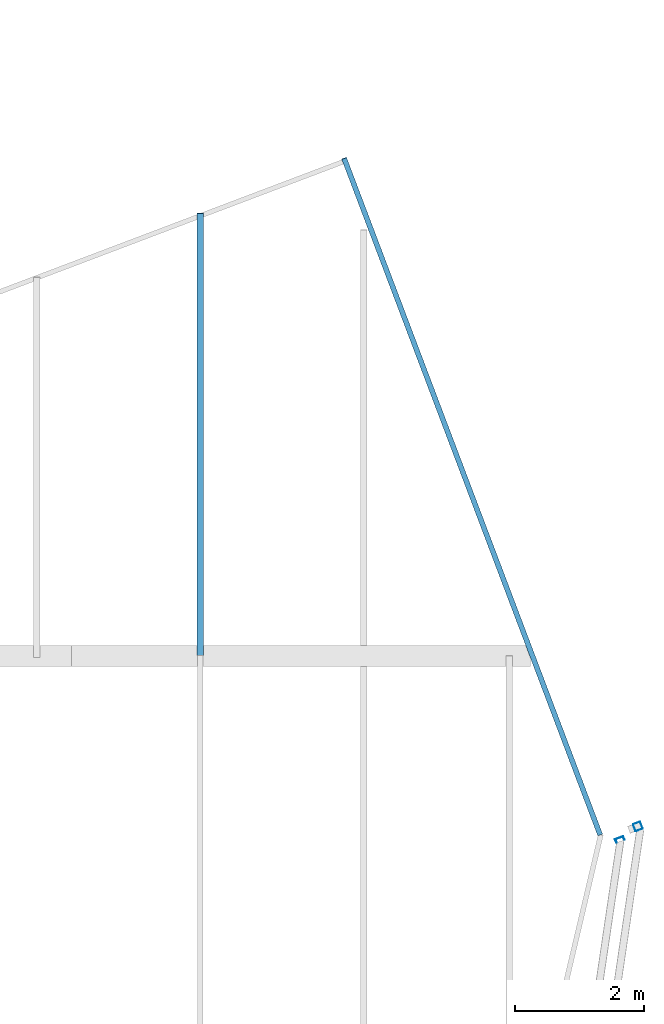
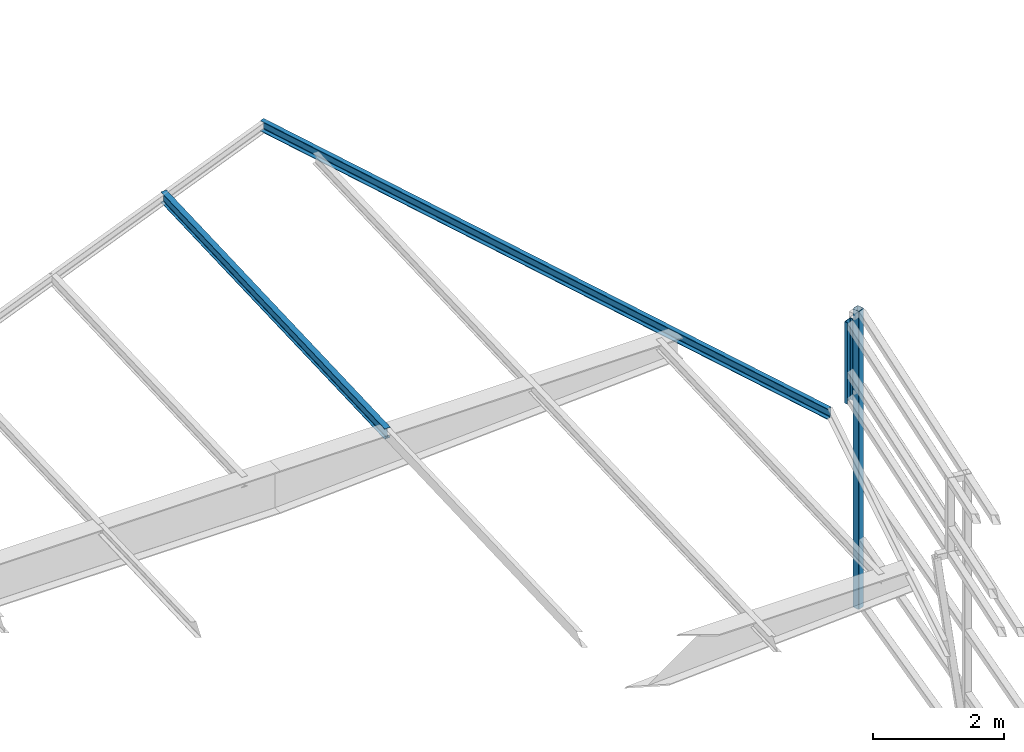
# One storey, part 136 of 215: 4 beams, 4 elements without a shape of their own.
"""IFC2X3 building model written with IfcOpenShell, lengths in millimetres."""

from ifc_helpers import new_model, si_unit, frame, origin_with_axes, origin_2d_with_axis, place, context, subcontext, project, spatial, hollow_rectangle, i_section, u_section, extrude, material, type_object, element, aggregate, save


model = new_model("IFC2X3")

# Units and contexts
model_context = context("Model", 3, precision=1e-05, world=origin_with_axes())
body_context = subcontext(model_context, "Body", "Model", "MODEL_VIEW")
ifc_project = project(units=[si_unit("LENGTHUNIT", "METRE", prefix="MILLI"), si_unit("AREAUNIT", "SQUARE_METRE"), si_unit("VOLUMEUNIT", "CUBIC_METRE"), si_unit("MASSUNIT", "GRAM", prefix="KILO"), si_unit("TIMEUNIT", "SECOND"), si_unit("PLANEANGLEUNIT", "RADIAN"), si_unit("SOLIDANGLEUNIT", "STERADIAN"), si_unit("THERMODYNAMICTEMPERATUREUNIT", "DEGREE_CELSIUS"), si_unit("LUMINOUSINTENSITYUNIT", "LUMEN")], contexts=[model_context])

# Site, building, storey
site_placement = place(None, origin_with_axes())
site = spatial("IfcSite", under=ifc_project, at=site_placement, CompositionType="ELEMENT")
building_placement = place(site_placement, origin_with_axes())
building = spatial("IfcBuilding", under=site, at=building_placement, Name="Undefined", CompositionType="ELEMENT")
storey_placement = place(building_placement, origin_with_axes())
storey = spatial("IfcBuildingStorey", under=building, at=storey_placement, Name="Undefined", CompositionType="ELEMENT", Elevation=0.0)

# Assembly, beam
assembly_1_placement = place(storey_placement, origin_with_axes())
assembly_1 = element("IfcElementAssembly", 1, at=assembly_1_placement, inside=storey, Name="Steel Assembly", AssemblyPlace="NOTDEFINED", PredefinedType="RIGID_FRAME")
ifc_material = material(Name="STEEL/S275JR")
beam_type_1 = type_object("IfcBeamType", PredefinedType="NOTDEFINED")
beam_1_placement = place(assembly_1_placement, frame((154097.457120588, 66742.6425860684, 5773.10153044516), z_axis=(0.935074624308728, 0.354450909117033, -1.00000033886592e-09), x_axis=(0.0, 0.0, -1.0)))
beam_1 = element("IfcBeam", 2, at=beam_1_placement, type_object=beam_type_1, material=ifc_material, Name="LISSE", context=body_context, shape_type="SweptSolid", body=[
    extrude(hollow_rectangle(XDim=120.0, YDim=120.0, WallThickness=4.0, InnerFilletRadius=4.0, OuterFilletRadius=8.0, at=origin_2d_with_axis()), frame((5576.99931204608, 2.72848410531878e-12, 0.0), z_axis=(-1.0, 0.0, 0.0), x_axis=(-6.93889390390723e-18, -1.0, -3.46944695195361e-18)), (0.0, 0.0, 1.0), 5577.0),
])
aggregate(assembly_1, [beam_1])

assembly_2_placement = place(storey_placement, origin_with_axes())
assembly_2 = element("IfcElementAssembly", 3, at=assembly_2_placement, inside=storey, Name="Steel Assembly", AssemblyPlace="NOTDEFINED", PredefinedType="RIGID_FRAME")
beam_type_2 = type_object("IfcBeamType", Name="UPN140", PredefinedType="NOTDEFINED")
beam_2_placement = place(assembly_2_placement, frame((153815.84693232, 66541.0720507958, 5773.09994612341), z_axis=(0.935132179815653, 0.354299033930157, 2.87989999940312e-05), x_axis=(8.63999999908537e-06, 5.84800000139875e-05, -0.99999999825272)))
beam_2 = element("IfcBeam", 4, at=beam_2_placement, type_object=beam_type_2, material=ifc_material, Name="LISSE", ObjectType="UPN140", context=body_context, shape_type="SweptSolid", body=[
    extrude(u_section(Depth=140.0, FlangeWidth=60.0, WebThickness=7.0, FlangeThickness=10.0, FilletRadius=10.0, EdgeRadius=5.0, FlangeSlope=0.0798299857122373, at=origin_2d_with_axis()), frame((1522.46856402286, -1.81898940354586e-12, 0.0), z_axis=(-1.0, 0.0, 0.0), x_axis=(-6.93889390390723e-18, -1.0, -3.46944695195361e-18)), (0.0, 0.0, 1.0), 1522.5),
])
aggregate(assembly_2, [beam_2])

assembly_3_placement = place(storey_placement, origin_with_axes())
assembly_3 = element("IfcElementAssembly", 5, at=assembly_3_placement, inside=storey, Name="Steel Assembly", AssemblyPlace="NOTDEFINED", PredefinedType="RIGID_FRAME")
beam_type_3 = type_object("IfcBeamType", Name="UPE200", PredefinedType="NOTDEFINED")
beam_3_placement = place(assembly_3_placement, frame((149536.955130954, 77114.6864918704, 4515.82497532615), z_axis=(0.0132321800021827, -0.034957242005792, 0.999301206165458), x_axis=(0.353764427894475, -0.934587411721224, -0.0373777929888507)))
beam_3 = element("IfcBeam", 6, at=beam_3_placement, type_object=beam_type_3, material=ifc_material, ObjectType="UPE200", context=body_context, shape_type="SweptSolid", body=[
    extrude(u_section(Depth=200.0, FlangeWidth=80.0, WebThickness=6.0, FlangeThickness=11.0, FilletRadius=13.0, at=origin_2d_with_axis()), frame((11234.6380049323, -2.83515100463267e-11, 3.76791389721435e-13), z_axis=(-1.0, 0.0, 0.0), x_axis=(-6.93889390390723e-18, -1.0, -3.46944695195361e-18)), (0.0, 0.0, 1.0), 11234.6),
])
aggregate(assembly_3, [beam_3])

assembly_4_placement = place(storey_placement, origin_with_axes())
assembly_4 = element("IfcElementAssembly", 7, at=assembly_4_placement, inside=storey, Name="Steel Assembly", AssemblyPlace="NOTDEFINED", PredefinedType="RIGID_FRAME")
beam_type_4 = type_object("IfcBeamType", Name="IPE200", PredefinedType="NOTDEFINED")
beam_4_placement = place(assembly_4_placement, frame((147305.01029117, 69397.4326639491, 4206.65626849463), z_axis=(-2.1980000026525e-06, -0.0399625230126959, 0.999201179317573), x_axis=(0.0, 0.999201183199638, 0.0399624260079844)))
beam_4 = element("IfcBeam", 8, at=beam_4_placement, type_object=beam_type_4, material=ifc_material, ObjectType="IPE200", context=body_context, shape_type="SweptSolid", body=[
    extrude(i_section(OverallWidth=100.0, OverallDepth=200.0, WebThickness=5.599999905, FlangeThickness=8.5, FilletRadius=12.0, at=origin_2d_with_axis()), frame((6867.75014618848, -2.91038304567337e-11, -6.82121026329696e-13), z_axis=(-1.0, 0.0, 0.0), x_axis=(-6.93889390390723e-18, -1.0, -3.46944695195361e-18)), (0.0, 0.0, 1.0), 6867.8),
])
aggregate(assembly_4, [beam_4])

save(model, "model.ifc")
